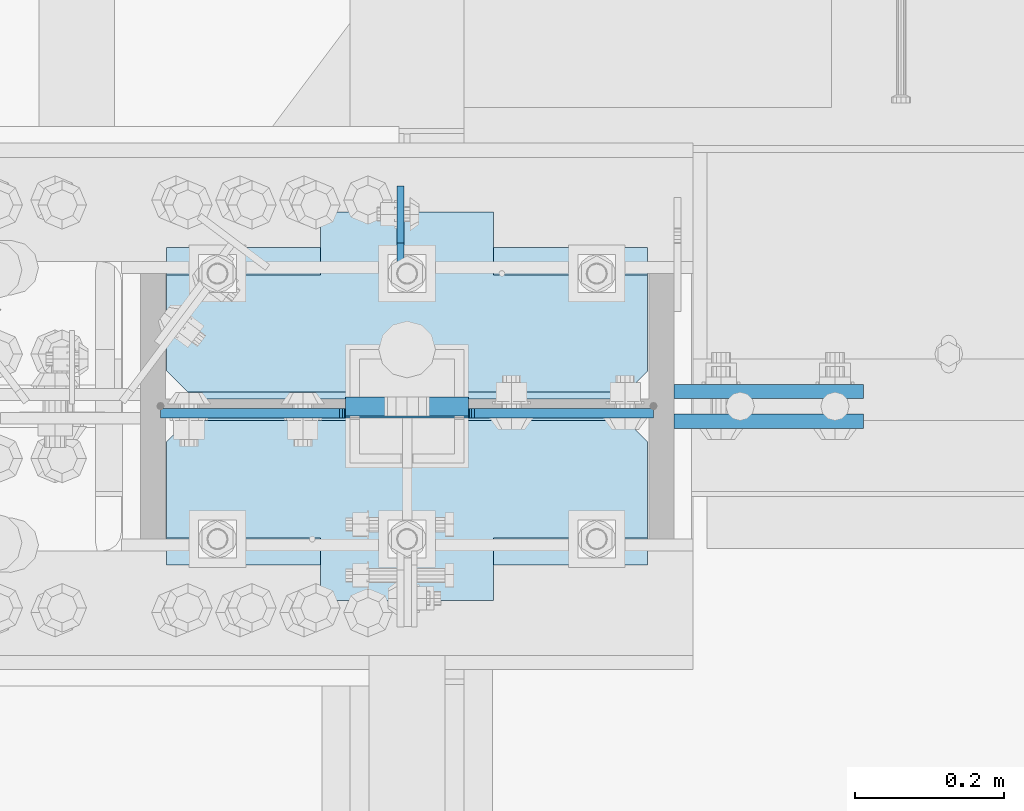
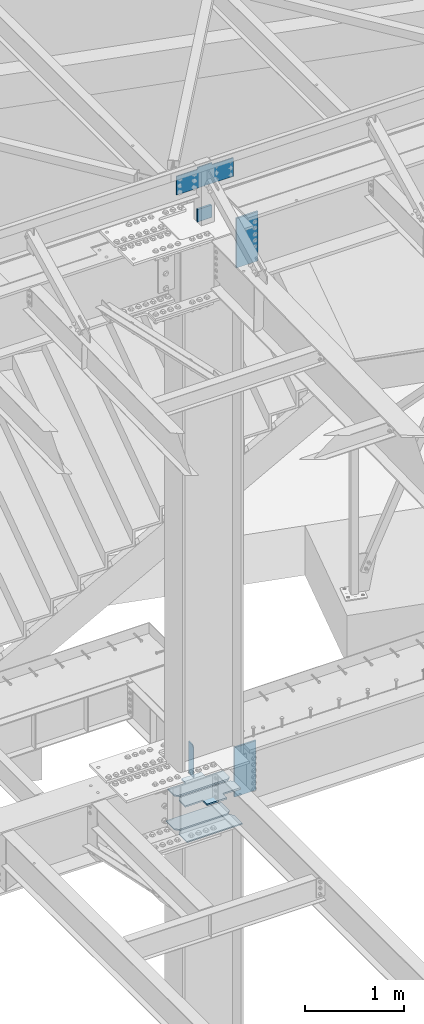
# One storey, part 1640 of 1763: 9 plates, 2 elements without a shape of their own.
"""IFC2X3 building model written with IfcOpenShell, lengths in millimetres."""

from ifc_helpers import new_model, si_unit, frame, origin_with_axes, place, context, subcontext, project, spatial, faceted_brep, material, type_object, element, aggregate, save


model = new_model("IFC2X3")

# Units and contexts
model_context = context("Model", 3, precision=1e-05, world=origin_with_axes())
body_context = subcontext(model_context, "Body", "Model", "MODEL_VIEW")
ifc_project = project(units=[si_unit("LENGTHUNIT", "METRE", prefix="MILLI"), si_unit("AREAUNIT", "SQUARE_METRE"), si_unit("VOLUMEUNIT", "CUBIC_METRE"), si_unit("MASSUNIT", "GRAM", prefix="KILO"), si_unit("TIMEUNIT", "SECOND"), si_unit("PLANEANGLEUNIT", "RADIAN"), si_unit("SOLIDANGLEUNIT", "STERADIAN"), si_unit("THERMODYNAMICTEMPERATUREUNIT", "DEGREE_CELSIUS"), si_unit("LUMINOUSINTENSITYUNIT", "LUMEN")], contexts=[model_context])

# Site, building, storey
site_placement = place(None, origin_with_axes())
site = spatial("IfcSite", under=ifc_project, at=site_placement, CompositionType="ELEMENT")
building_placement = place(site_placement, origin_with_axes())
building = spatial("IfcBuilding", under=site, at=building_placement, Name="Undefined", CompositionType="ELEMENT")
storey_placement = place(building_placement, origin_with_axes())
storey = spatial("IfcBuildingStorey", under=building, at=storey_placement, Name="Undefined", CompositionType="ELEMENT", Elevation=0.0)

# Assembly, plates
assembly_1_placement = place(storey_placement, origin_with_axes())
assembly_1 = element("IfcElementAssembly", 1, at=assembly_1_placement, inside=storey, Name="COLUMN", AssemblyPlace="NOTDEFINED", PredefinedType="RIGID_FRAME")
ifc_material_1 = material(Name="STEEL/A572-50")
plate_type_1 = type_object("IfcPlateType", PredefinedType="NOTDEFINED")
plate_1_placement = place(assembly_1_placement, frame((-35272.0997736983, 51908.075, 4335.4625), z_axis=(1.0, 0.0, 0.0), x_axis=(0.0, 1.0, 0.0)))
plate_1 = element("IfcPlate", 2, at=plate_1_placement, type_object=plate_type_1, material=ifc_material_1, Name="HORIZONTAL SHEAR PLAT", context=body_context, shape_type="Brep", body=[
    faceted_brep([(-7.27595761418343e-12, -7.9375, 0.0), (0.0, -7.9375, 644.524963378906), (0.0, 7.9375, 644.524963378906), (-7.27595761418343e-12, 7.9375, 0.0), (165.099998474121, -7.9375, 644.524963378906), (165.099998474121, 7.9375, 644.524963378906), (203.199996948242, -7.9375, 606.424964904785), (203.199996948242, 7.9375, 606.424964904785), (203.199996948242, -7.9375, 38.0999984741211), (203.199996948242, 7.9375, 38.0999984741211), (165.099998474121, -7.9375, 0.0), (165.099998474121, 7.9375, 0.0)], [[[0, 1, 2, 3]], [[1, 4, 5, 2]], [[4, 6, 7, 5]], [[6, 8, 9, 7]], [[8, 10, 11, 9]], [[10, 0, 3, 11]], [[5, 7, 9, 11, 3, 2]], [[10, 8, 6, 4, 1, 0]]]),
])
plate_2_placement = place(assembly_1_placement, frame((-35272.0997736983, 52333.525, 4335.4625), z_axis=(1.0, 0.0, 0.0), x_axis=(0.0, -1.0, 0.0)))
plate_2 = element("IfcPlate", 3, at=plate_2_placement, type_object=plate_type_1, material=ifc_material_1, Name="HORIZONTAL SHEAR PLAT", context=body_context, shape_type="Brep", body=[
    faceted_brep([(-7.27595761418343e-12, -7.9375, 0.0), (0.0, -7.9375, 644.524963378906), (0.0, 7.9375, 644.524963378906), (-7.27595761418343e-12, 7.9375, 0.0), (165.099998474121, -7.9375, 644.524963378906), (165.099998474121, 7.9375, 644.524963378906), (203.199996948242, -7.9375, 606.424964904785), (203.199996948242, 7.9375, 606.424964904785), (203.199996948242, -7.9375, 38.0999984741211), (203.199996948242, 7.9375, 38.0999984741211), (165.099998474121, -7.9375, 0.0), (165.099998474121, 7.9375, 0.0)], [[[0, 1, 2, 3]], [[1, 4, 5, 2]], [[4, 6, 7, 5]], [[6, 8, 9, 7]], [[8, 10, 11, 9]], [[10, 0, 3, 11]], [[5, 7, 9, 11, 3, 2]], [[10, 8, 6, 4, 1, 0]]]),
])
plate_type_2 = type_object("IfcPlateType", PredefinedType="NOTDEFINED")
plate_3_placement = place(assembly_1_placement, frame((-34867.2872721725, 52120.8, 11912.5999909009), z_axis=(0.0, 0.0, -1.0), x_axis=(-1.0, 0.0, 0.0)))
plate_3 = element("IfcPlate", 4, at=plate_3_placement, type_object=plate_type_2, material=ifc_material_1, Name="PLATE", context=body_context, shape_type="Brep", body=[
    faceted_brep([(0.0, 12.7, 152.399990844726), (-1.45519152283669e-11, 7.27595761418343e-12, 165.099990844727), (165.099990844727, 0.0, 165.099990844727), (165.099990844727, 12.7, 152.399990844726), (0.0, -12.7, 152.399990844726), (165.099990844727, -12.7, 152.399990844726), (0.0, 12.6999999999971, -1.81898940354586e-12), (0.0, -12.6999999999971, -1.81898940354586e-12), (165.099990844727, -12.7, 0.0), (165.099990844727, 12.7, 0.0)], [[[0, 1, 2, 3]], [[1, 4, 5, 2]], [[6, 7, 4, 1, 0]], [[5, 8, 9, 3, 2]], [[8, 7, 6, 9]], [[9, 6, 0, 3]], [[7, 8, 5, 4]]]),
])
ifc_material_2 = material(Name="STEEL/A572-GR.50")
plate_type_3 = type_object("IfcPlateType", PredefinedType="NOTDEFINED")
plate_4_placement = place(assembly_1_placement, frame((-34958.5685236983, 52314.475, 5165.725), z_axis=(0.0, 1.0, 0.0), x_axis=(0.0, 0.0, -1.0)))
plate_4 = element("IfcPlate", 5, at=plate_4_placement, type_object=plate_type_3, material=ifc_material_2, Name="PLATE", context=body_context, shape_type="Brep", body=[
    faceted_brep([(25.3999996185303, -4.76250000000073, 0.0), (0.0, -4.76250000000073, 25.3999996185303), (0.0, 4.76250000000073, 25.3999996185303), (25.3999996185303, 4.76250000000073, 0.0), (1.45519152283669e-11, -4.76250000000448, 101.60001373291), (390.524993896484, -4.76249999999709, 101.599998474121), (390.524993896484, 4.76249999999709, 101.599998474121), (0.0, 4.76250000000243, 101.60001373291), (390.524993896484, -4.76249999999709, 0.0), (390.524993896484, 4.76249999999709, 0.0)], [[[0, 1, 2, 3]], [[4, 5, 6, 7]], [[5, 8, 9, 6]], [[9, 8, 0, 3]], [[7, 6, 9, 3, 2]], [[4, 7, 2, 1]], [[8, 5, 4, 1, 0]]]),
])

# Assembly, plate
assembly_2_placement = place(storey_placement, origin_with_axes())
assembly_2 = element("IfcElementAssembly", 6, at=assembly_2_placement, inside=storey, Name="COLUMN", AssemblyPlace="NOTDEFINED", PredefinedType="RIGID_FRAME")
plate_type_4 = type_object("IfcPlateType", PredefinedType="NOTDEFINED")
plate_5_placement = place(assembly_2_placement, frame((-35032.387273697, 52111.2750001099, 12433.3), z_axis=(0.0, 0.0, -1.0), x_axis=(1.0, 0.0, 0.0)))
plate_5 = element("IfcPlate", 7, at=plate_5_placement, type_object=plate_type_4, material=ifc_material_1, Name="PLATE", context=body_context, shape_type="Brep", body=[
    faceted_brep([(-247.649993896484, -6.34999999999854, 25.3999996185303), (-247.649993896484, 6.34999999999854, 25.3999996185303), (-12.6999998092724, 6.34999999999854, 25.3999996185303), (-12.6999998092724, -6.34999999999854, 25.3999996185303), (-7.83992029122601, 6.34999999999854, 24.4332696959427), (-7.83992029122601, -6.34999999999854, 24.4332696959427), (-3.71974382307235, 6.34999999999854, 21.6802557954652), (-3.71974382307235, -6.34999999999854, 21.6802557954652), (-0.966729922594823, 6.34999999999854, 17.5600793273115), (-0.966729922594823, -6.34999999999854, 17.5600793273115), (-1.31614667686587e-12, -6.35, 12.6999998092651), (-1.06936913171421e-12, 6.34999923705982, 12.699999332428), (0.0, 6.34999999999491, -2.91038304567337e-11), (0.0, -6.34999999999491, 1.45519152283669e-11), (-247.649993896484, -6.34999999999854, 254.0), (412.75, -6.34999999999854, 254.0), (412.75, 6.34999999999854, 254.0), (-247.649993896484, 6.34999999999854, 254.0), (412.75, -6.34999999999854, 25.3999996185303), (412.75, 6.34999999999854, 25.3999996185303), (177.800005912781, -6.34999999999854, 25.3999996185303), (177.800005912781, 6.34999999999854, 25.3999996185303), (172.939926394734, -6.34999999999854, 24.4332696959427), (172.939926394734, 6.34999999999854, 24.4332696959427), (168.819749926581, -6.34999999999854, 21.6802557954652), (168.819749926581, 6.34999999999854, 21.6802557954652), (166.066736026103, -6.34999999999854, 17.5600793273115), (166.066736026103, 6.34999999999854, 17.5600793273115), (165.100006103516, -6.34999999999854, 12.6999998092651), (165.100006103516, 6.34999999999854, 12.6999998092651), (165.100006103516, -6.34999999999854, 0.0), (165.100006103516, 6.34999999999854, 0.0)], [[[0, 1, 2, 3]], [[3, 2, 4, 5]], [[5, 4, 6, 7]], [[7, 6, 8, 9]], [[10, 11, 12, 13]], [[9, 8, 11, 10]], [[14, 15, 16, 17]], [[15, 18, 19, 16]], [[18, 20, 21, 19]], [[20, 22, 23, 21]], [[22, 24, 25, 23]], [[24, 26, 27, 25]], [[26, 28, 29, 27]], [[28, 30, 31, 29]], [[31, 30, 13, 12]], [[6, 4, 2, 1, 17, 16, 19, 21, 23, 25, 27, 29, 31, 12, 11, 8]], [[14, 17, 1, 0]], [[30, 28, 26, 24, 22, 20, 18, 15, 14, 0, 3, 5, 7, 9, 10, 13]]]),
])
aggregate(assembly_2, [plate_5])

# Plate
plate_type_5 = type_object("IfcPlateType", PredefinedType="NOTDEFINED")
plate_6_placement = place(assembly_1_placement, frame((-34592.6497736984, 52100.9562502128, 11658.5999917654), z_axis=(1.0, 0.0, 0.0), x_axis=(0.0, 0.0, -1.0)))
plate_6 = element("IfcPlate", 8, at=plate_6_placement, type_object=plate_type_5, material=ifc_material_1, Name="PLATE", context=body_context, shape_type="Brep", body=[
    faceted_brep([(0.0, -9.52500000000146, 0.0), (1.13504938781261e-09, -9.52499999999964, 254.000000000065), (1.13504938781261e-09, 9.52499999999964, 254.000000000065), (0.0, 9.52500000000146, 0.0), (609.599975585938, -9.52499999999418, 254.0), (609.599975585938, 9.52499999999418, 254.0), (609.599975585938, -9.52499999999418, 0.0), (609.599975585938, 9.52499999999418, 0.0)], [[[0, 1, 2, 3]], [[1, 4, 5, 2]], [[4, 6, 7, 5]], [[6, 0, 3, 7]], [[5, 7, 3, 2]], [[6, 4, 1, 0]]]),
])

plate_7_placement = place(assembly_1_placement, frame((-34592.6497736984, 52140.64375, 5124.45), z_axis=(1.0, 0.0, 0.0), x_axis=(0.0, 0.0, -1.0)))
plate_7 = element("IfcPlate", 9, at=plate_7_placement, type_object=plate_type_5, material=ifc_material_1, Name="PLATE", context=body_context, shape_type="Brep", body=[
    faceted_brep([(0.0, -9.52500000000146, 0.0), (1.13504938781261e-09, -9.52499999999964, 254.000000000065), (1.13504938781261e-09, 9.52499999999964, 254.000000000065), (0.0, 9.52500000000146, 0.0), (609.599975585938, -9.52499999999418, 254.0), (609.599975585938, 9.52499999999418, 254.0), (609.599975585938, -9.52499999999418, 0.0), (609.599975585938, 9.52499999999418, 0.0)], [[[0, 1, 2, 3]], [[1, 4, 5, 2]], [[4, 6, 7, 5]], [[6, 0, 3, 7]], [[5, 7, 3, 2]], [[6, 4, 1, 0]]]),
])

plate_type_6 = type_object("IfcPlateType", PredefinedType="NOTDEFINED")
plate_8_placement = place(assembly_1_placement, frame((-34627.5747736984, 51860.45, 4749.8), z_axis=(-1.0, 0.0, 0.0), x_axis=(0.0, 1.0, 0.0)))
plate_8 = element("IfcPlate", 10, at=plate_8_placement, type_object=plate_type_6, material=ifc_material_1, Name="PLATE", context=body_context, shape_type="Brep", body=[
    faceted_brep([(250.824996948242, -7.65116965339985e-07, 606.425025939941), (241.299997713359, -9.52499999999964, 615.950025174825), (241.299997713359, -9.52499999999964, 28.5749992392375), (250.824996948242, -7.65116965339985e-07, 38.0999984741211), (212.724998474121, -9.52499999999964, 644.525024414062), (212.724998474121, 9.52499999999964, 644.525024414062), (84.1374937417932, 9.52499999999964, 644.525024414062), (84.1374937417932, -9.52499999999964, 644.525015258841), (84.1374936944267, 9.52499999999964, 438.150000000052), (84.1374936944267, -9.52499999999964, 438.150000000052), (0.0, 9.52499999999964, 438.149991923026), (0.0, -9.52499999999964, 438.149991923026), (0.0, 9.52499999999964, 206.375007181632), (0.0, -9.52499999999964, 206.375007181632), (212.724998474121, 9.52499999999964, 0.0), (212.724998474121, -9.52499999999964, 0.0), (84.1374937194487, -9.52499999999964, 0.0), (84.1374937194487, 9.52499999999964, 0.0), (84.1374937668224, -9.52499999999964, 206.375015258745), (84.1374937668224, 9.52499999999964, 206.375015258745), (250.824996948242, 9.52499999999964, 606.425025939941), (250.824996948242, 9.52499999999964, 38.0999984741211)], [[[0, 1, 2, 3]], [[4, 5, 6, 7]], [[7, 6, 8, 9]], [[9, 8, 10, 11]], [[11, 10, 12, 13]], [[14, 15, 16, 17]], [[18, 19, 17, 16]], [[13, 12, 19, 18]], [[10, 8, 6, 5, 20, 21, 14, 17, 19, 12]], [[21, 20, 0, 3]], [[15, 14, 21, 3, 2]], [[4, 7, 9, 11, 13, 18, 16, 15, 2, 1]], [[20, 5, 4, 1, 0]]]),
])

plate_9_placement = place(assembly_1_placement, frame((-34627.5747736984, 52130.325, 4749.8), z_axis=(-1.0, 0.0, 0.0), x_axis=(0.0, 1.0, 0.0)))
plate_9 = element("IfcPlate", 11, at=plate_9_placement, type_object=plate_type_6, material=ifc_material_1, Name="PLATE", context=body_context, shape_type="Brep", body=[
    faceted_brep([(9.52499923488358, -9.52499999999964, 615.950025174825), (0.0, -7.65116965339985e-07, 606.425025939941), (0.0, 0.0, 38.0999984741211), (9.52499923488358, -9.52499999999964, 28.5749992392375), (250.824996948075, -9.52499999999964, 438.150000000038), (250.824996948242, 9.52499999999964, 438.150000000038), (166.687499999833, 9.52499999999964, 438.149991923055), (166.687499999833, -9.52499999999964, 438.149991923055), (250.824996970761, -9.52499999999964, 206.375015258731), (250.824996948242, 9.52499999999964, 206.375015258731), (38.0999984741211, -9.52500000000146, 0.0), (38.0999984741211, 9.52500000000146, 0.0), (166.6875, 9.52499999999964, 0.0), (166.6875, -9.52499999999964, 0.0), (166.687503076391, 9.52499999999964, 206.375007181618), (166.687503076391, -9.52499999999964, 206.375007181618), (0.0, 9.52500000000146, 38.0999984741211), (0.0, 9.52499999999964, 606.425025939941), (38.0999984741211, 9.52499999999964, 644.525024414062), (166.687503076224, 9.52499999999964, 644.525024414062), (166.687503076224, -9.52499999999964, 644.525024414062), (38.0999984741211, -9.52499999999964, 644.525024414062)], [[[0, 1, 2, 3]], [[4, 5, 6, 7]], [[5, 4, 8, 9]], [[10, 11, 12, 13]], [[13, 12, 14, 15]], [[8, 15, 14, 9]], [[12, 11, 16, 17, 18, 19, 6, 5, 9, 14]], [[20, 7, 6, 19]], [[18, 21, 20, 19]], [[10, 13, 15, 8, 4, 7, 20, 21, 0, 3]], [[16, 11, 10, 3, 2]], [[17, 16, 2, 1]], [[21, 18, 17, 1, 0]]]),
])

aggregate(assembly_1, [plate_1, plate_2, plate_8, plate_9, plate_4, plate_3, plate_6, plate_7])

save(model, "model.ifc")
